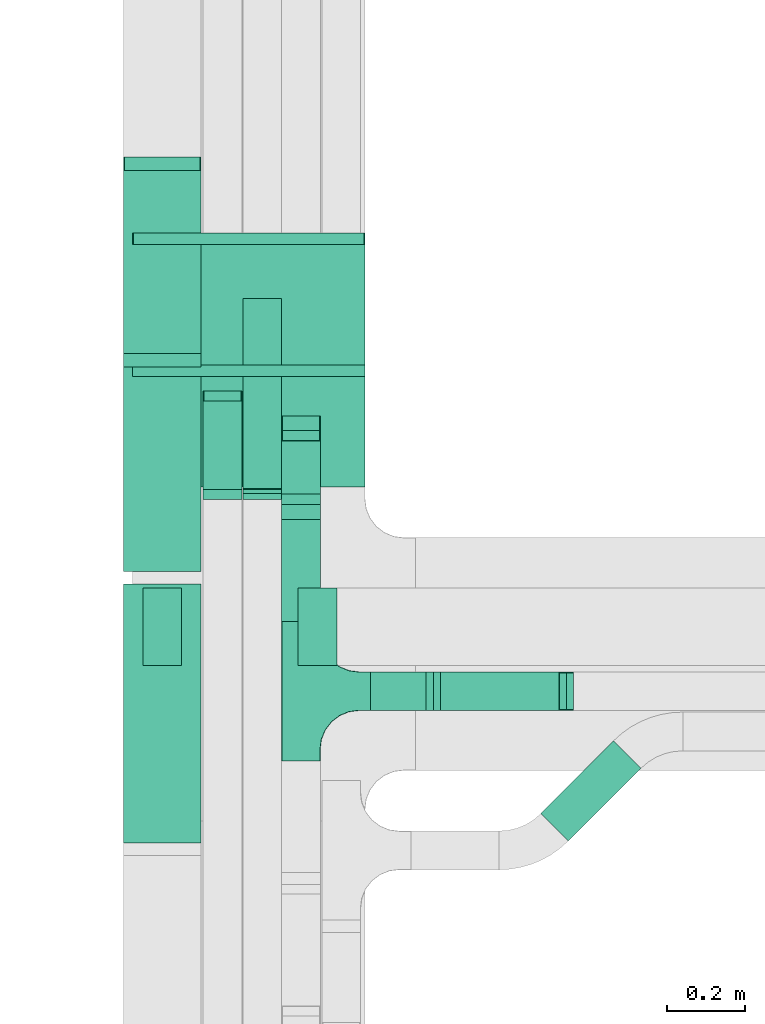
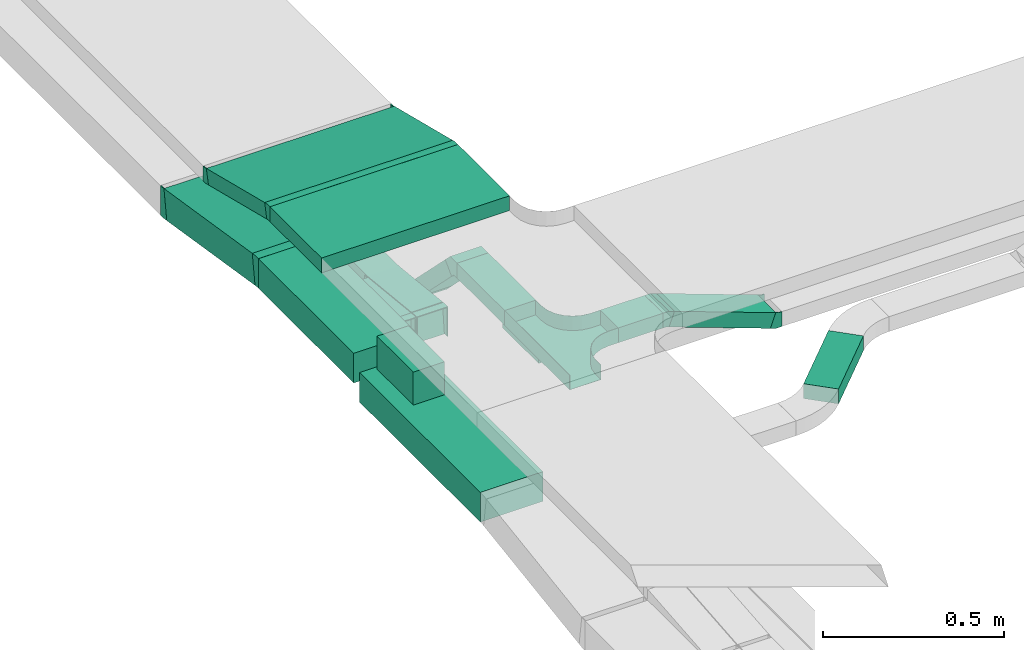
# One storey, part 31 of 38: 14 flow segments, 13 flow fittings.
"""IFC2X3 building model written with IfcOpenShell, lengths in millimetres."""

from ifc_helpers import new_model, entity, si_unit, converted_unit, derived_unit, direction, frame, frame_2d, origin, origin_2d_with_axis, place, context, subcontext, project, spatial, polyline, circle_curve, parameter, trimmed, segment, composite_curve, rectangle, outline, extrude, faceted_brep, source, transform, mapped, material, type_object, type_shapes, element, save


model = new_model("IFC2X3")

# Units and contexts
model_context = context("Model", 3, precision=0.01, world=origin(), true_north=direction((6.12303176911189e-17, 1.0)))
body_context = subcontext(model_context, "Body", "Model", "MODEL_VIEW")
ifc_project = project(units=[si_unit("LENGTHUNIT", "METRE", prefix="MILLI"), si_unit("AREAUNIT", "SQUARE_METRE"), si_unit("VOLUMEUNIT", "CUBIC_METRE"), converted_unit("PLANEANGLEUNIT", "DEGREE", entity("IfcRatioMeasure", 0.0174532925199433), si_unit("PLANEANGLEUNIT", "RADIAN"), dimensions=[0, 0, 0, 0, 0, 0, 0]), si_unit("MASSUNIT", "GRAM", prefix="KILO"), derived_unit("MASSDENSITYUNIT", [(si_unit("MASSUNIT", "GRAM", prefix="KILO"), 1), (si_unit("LENGTHUNIT", "METRE"), -3)]), derived_unit("MOMENTOFINERTIAUNIT", [(si_unit("LENGTHUNIT", "METRE"), 4)]), si_unit("TIMEUNIT", "SECOND"), si_unit("FREQUENCYUNIT", "HERTZ"), si_unit("THERMODYNAMICTEMPERATUREUNIT", "DEGREE_CELSIUS"), derived_unit("THERMALTRANSMITTANCEUNIT", [(si_unit("MASSUNIT", "GRAM", prefix="KILO"), 1), (si_unit("THERMODYNAMICTEMPERATUREUNIT", "KELVIN"), -1), (si_unit("TIMEUNIT", "SECOND"), -3)]), derived_unit("VOLUMETRICFLOWRATEUNIT", [(si_unit("LENGTHUNIT", "METRE"), 3), (si_unit("TIMEUNIT", "SECOND"), -1)]), derived_unit("MASSFLOWRATEUNIT", [(si_unit("MASSUNIT", "GRAM", prefix="KILO"), 1), (si_unit("TIMEUNIT", "SECOND"), -1)]), derived_unit("ROTATIONALFREQUENCYUNIT", [(si_unit("TIMEUNIT", "SECOND"), -1)]), si_unit("ELECTRICCURRENTUNIT", "AMPERE"), si_unit("ELECTRICVOLTAGEUNIT", "VOLT"), si_unit("POWERUNIT", "WATT"), si_unit("FORCEUNIT", "NEWTON", prefix="KILO"), si_unit("ILLUMINANCEUNIT", "LUX"), si_unit("LUMINOUSFLUXUNIT", "LUMEN"), si_unit("LUMINOUSINTENSITYUNIT", "CANDELA"), derived_unit("USERDEFINED", [(si_unit("MASSUNIT", "GRAM", prefix="KILO"), -1), (si_unit("LENGTHUNIT", "METRE"), -2), (si_unit("TIMEUNIT", "SECOND"), 3), (si_unit("LUMINOUSFLUXUNIT", "LUMEN"), 1)]), derived_unit("LINEARVELOCITYUNIT", [(si_unit("LENGTHUNIT", "METRE"), 1), (si_unit("TIMEUNIT", "SECOND"), -1)]), si_unit("PRESSUREUNIT", "PASCAL"), derived_unit("USERDEFINED", [(si_unit("LENGTHUNIT", "METRE"), -2), (si_unit("MASSUNIT", "GRAM", prefix="KILO"), 1), (si_unit("TIMEUNIT", "SECOND"), -2)]), derived_unit("LINEARFORCEUNIT", [(si_unit("MASSUNIT", "GRAM", prefix="KILO"), 1), (si_unit("LENGTHUNIT", "METRE"), 1), (si_unit("TIMEUNIT", "SECOND"), -2), (si_unit("LENGTHUNIT", "METRE"), -1)]), derived_unit("PLANARFORCEUNIT", [(si_unit("MASSUNIT", "GRAM", prefix="KILO"), 1), (si_unit("LENGTHUNIT", "METRE"), 1), (si_unit("TIMEUNIT", "SECOND"), -2), (si_unit("LENGTHUNIT", "METRE"), -2)])], contexts=[model_context])

# Site, building, storey
site_placement = place(None, frame((0.0, -0.00077364408347762, 0.0)))
site = spatial("IfcSite", under=ifc_project, at=site_placement, CompositionType="ELEMENT")
building_placement = place(site_placement, origin())
building = spatial("IfcBuilding", under=site, at=building_placement, CompositionType="ELEMENT")
storey_placement = place(building_placement, frame((0.0, 0.0, 4200.0)))
storey = spatial("IfcBuildingStorey", under=building, at=storey_placement, CompositionType="ELEMENT", Elevation=4200.0)

# Flow segments
cable_carrier_segment_type = type_object("IfcCableCarrierSegmentType", PredefinedType="CABLETRAYSEGMENT")
flow_segment_1_placement = place(storey_placement, frame((61494.0334115341, 9426.19882901523, 2776.99060375594)))
element("IfcFlowSegment", 1, at=flow_segment_1_placement, inside=storey, type_object=cable_carrier_segment_type, context=body_context, shape_type="SweptSolid", body=[
    extrude(rectangle(XDim=49.9999999999996, YDim=332.374456454339, at=frame_2d((1.4210854715202e-13, -5.27577981301874e-13), x_axis=(0.0, 1.0))), frame((0.0, 167.298804700468, 64.4617224340722), z_axis=(1.0, 0.0, 0.0), x_axis=(0.0, -0.970295726275995, 0.241921895599672)), (0.0, 0.0, 1.0), 600.000000000002),
])
flow_segment_2_placement = place(storey_placement, frame((61494.0334115341, 9123.32381905951, 2859.5)))
element("IfcFlowSegment", 2, at=flow_segment_2_placement, inside=storey, type_object=cable_carrier_segment_type, context=body_context, shape_type="SweptSolid", body=[
    extrude(rectangle(XDim=285.765874456354, YDim=600.000000000002, at=origin_2d_with_axis()), frame((300.0, 142.882937228177, 0.0), z_axis=(0.0, 0.0, 1.0), x_axis=(0.0, 1.0, 0.0)), (0.0, 0.0, 1.0), 49.9999999999995),
])
flow_segment_3_placement = place(storey_placement, frame((61878.3352641976, 9070.34806579068, 2573.66699141101)))
element("IfcFlowSegment", 3, at=flow_segment_3_placement, inside=storey, type_object=cable_carrier_segment_type, context=body_context, shape_type="SweptSolid", body=[
    extrude(rectangle(XDim=50.0000000000003, YDim=242.742091415324, at=frame_2d((-1.4210854715202e-14, -7.65609797781508e-13), x_axis=(0.0, 1.0))), frame((0.0, 103.499958989255, 103.499958989258), z_axis=(1.0, 0.0, 0.0), x_axis=(0.0, -0.707106781186556, 0.707106781186539)), (0.0, 0.0, 1.0), 99.9999999999946),
])
flow_segment_4_placement = place(storey_placement, frame((61878.3352641976, 8777.44796607604, 2757.63390080053)))
element("IfcFlowSegment", 4, at=flow_segment_4_placement, inside=storey, type_object=cable_carrier_segment_type, context=body_context, shape_type="SweptSolid", body=[
    extrude(rectangle(XDim=263.151349409973, YDim=99.9999999999946, at=frame_2d((5.54223333892878e-13, 0.0), x_axis=(1.0, 0.0))), frame((50.0, 131.575674704968, 6.82255366996287e-05), z_axis=(0.0, 5.18526979960657e-07, 1.0), x_axis=(0.0, 1.0, -5.18526979960657e-07)), (0.0, 0.0, 1.0), 49.9999999999932),
])
flow_segment_5_placement = place(storey_placement, frame((62108.3352641976, 8547.44797903922, 2757.6340372516)))
element("IfcFlowSegment", 5, at=flow_segment_5_placement, inside=storey, type_object=cable_carrier_segment_type, context=body_context, shape_type="SweptSolid", body=[
    extrude(rectangle(XDim=142.246356724546, YDim=100.000000000001, at=frame_2d((0.0, -1.08357767203415e-12), x_axis=(1.0, 0.0))), frame((71.1231783622731, 50.0, 0.0)), (0.0, 0.0, 1.0), 49.9999999999995),
])
flow_segment_6_placement = place(storey_placement, frame((62270.5406883258, 8547.44797903922, 2636.40393955217)))
element("IfcFlowSegment", 6, at=flow_segment_6_placement, inside=storey, type_object=cable_carrier_segment_type, context=body_context, shape_type="SweptSolid", body=[
    extrude(rectangle(XDim=49.9999999999965, YDim=100.000000000001, at=origin_2d_with_axis()), frame((8.55050358314202, 50.0, 141.203091126029), z_axis=(0.939692620785895, 0.0, -0.342020143325705), x_axis=(0.342020143325705, 0.0, 0.939692620785895)), (0.0, 0.0, 1.0), 344.163283664483),
])
flow_segment_7_placement = place(storey_placement, frame((61778.6830273062, 9106.66010814399, 2529.62188532879)))
element("IfcFlowSegment", 7, at=flow_segment_7_placement, inside=storey, type_object=cable_carrier_segment_type, context=body_context, shape_type="SweptSolid", body=[
    extrude(rectangle(XDim=2.73678962123566, YDim=99.9999999999946, at=frame_2d((-1.13364873044475e-12, 0.0), x_axis=(1.0, 0.0))), frame((50.0, 1.36089860066666, 0.14303620669796), z_axis=(0.0, 0.10452846326773, 0.994521895368265), x_axis=(0.0, -0.994521895368265, 0.10452846326773)), (0.0, 0.0, 1.0), 100.000000000001),
])
flow_segment_8_placement = place(storey_placement, frame((61676.2835022257, 9106.66506813766, 2504.7917187995)))
element("IfcFlowSegment", 8, at=flow_segment_8_placement, inside=storey, type_object=cable_carrier_segment_type, context=body_context, shape_type="SweptSolid", body=[
    extrude(rectangle(XDim=100.0, YDim=99.9999999999946, at=frame_2d((6.03961325396085e-14, 0.0), x_axis=(1.0, 0.0))), frame((50.0, 5.22642316339489, 74.8431041747855), z_axis=(0.0, 0.994521895368247, -0.104528463267908), x_axis=(0.0, 0.104528463267908, 0.994521895368247)), (0.0, 0.0, 1.0), 240.288708176998),
])
flow_segment_9_placement = place(storey_placement, frame((61471.1830273062, 9451.5580777934, 2548.89047953296)))
element("IfcFlowSegment", 9, at=flow_segment_9_placement, inside=storey, type_object=cable_carrier_segment_type, context=body_context, shape_type="SweptSolid", body=[
    extrude(rectangle(XDim=99.9999999999984, YDim=494.262005377991, at=frame_2d((-5.25801624462474e-13, -8.5265128291212e-14), x_axis=(0.0, 1.0))), frame((0.0, 251.910133207519, 88.0442232302831), z_axis=(1.0, 0.0, 0.0), x_axis=(0.0, -0.987688340595126, 0.156434465040307)), (0.0, 0.0, 1.0), 200.000000000007),
])
flow_segment_10_placement = place(storey_placement, frame((61471.1830273062, 8906.27941972979, 2627.66940552644)))
element("IfcFlowSegment", 10, at=flow_segment_10_placement, inside=storey, type_object=cable_carrier_segment_type, context=body_context, shape_type="SweptSolid", body=[
    extrude(rectangle(XDim=526.736320783405, YDim=200.000000000007, at=frame_2d((1.08002495835535e-12, 0.0), x_axis=(1.0, 0.0))), frame((100.0, 263.368160391717, 0.0), z_axis=(0.0, 0.0, 1.0), x_axis=(0.0, -1.0, 0.0)), (0.0, 0.0, 1.0), 100.000000000002),
])
flow_segment_11_placement = place(storey_placement, frame((62546.4770390633, 8211.11251924324, 2577.30800926447)))
element("IfcFlowSegment", 11, at=flow_segment_11_placement, inside=storey, type_object=cable_carrier_segment_type, context=body_context, shape_type="SweptSolid", body=[
    extrude(rectangle(XDim=265.58357237913, YDim=100.000000000002, at=frame_2d((-2.67164068645798e-12, 3.44257955475769e-12), x_axis=(1.0, 0.0))), frame((129.253311559847, 129.253311559845, 0.0), z_axis=(0.0, 0.0, 1.0), x_axis=(0.707106781186535, 0.70710678118656, 0.0)), (0.0, 0.0, 1.0), 49.9999999999995),
])
flow_segment_12_placement = place(storey_placement, frame((61471.1830273063, 8206.57842204228, 2582.6)))
element("IfcFlowSegment", 12, at=flow_segment_12_placement, inside=storey, type_object=cable_carrier_segment_type, context=body_context, shape_type="SweptSolid", body=[
    extrude(rectangle(XDim=667.207311601806, YDim=200.000000000007, at=frame_2d((5.40012479177676e-13, 0.0), x_axis=(1.0, 0.0))), frame((100.0, 333.603655800902, 0.0), z_axis=(0.0, 0.0, 1.0), x_axis=(0.0, 1.0, 0.0)), (0.0, 0.0, 1.0), 99.9999999999989),
])
flow_segment_13_placement = place(storey_placement, frame((61921.3628309272, 8663.78573364408, 2682.60000000003)))
element("IfcFlowSegment", 13, at=flow_segment_13_placement, inside=storey, type_object=cable_carrier_segment_type, context=body_context, shape_type="SweptSolid", body=[
    extrude(rectangle(XDim=200.0, YDim=99.9999999999946, at=frame_2d((-1.08713038571295e-12, 0.0), x_axis=(1.0, 0.0))), frame((50.0, 100.0, 0.0), z_axis=(0.0, 0.0, 1.0), x_axis=(0.0, -1.0, 0.0)), (0.0, 0.0, 1.0), 29.9999999999921),
])
flow_segment_14_placement = place(storey_placement, frame((61521.1830273063, 8663.78573364408, 2682.6)))
element("IfcFlowSegment", 14, at=flow_segment_14_placement, inside=storey, type_object=cable_carrier_segment_type, context=body_context, shape_type="SweptSolid", body=[
    extrude(rectangle(XDim=200.0, YDim=99.9999999999946, at=origin_2d_with_axis()), frame((50.0, 100.0, 0.0), z_axis=(0.0, 0.0, 1.0), x_axis=(0.0, 1.0, 0.0)), (0.0, 0.0, 1.0), 111.353041875385),
])

# Flow fittings
ifc_material = material()
cable_carrier_fitting_type_1 = type_object("IfcCableCarrierFittingType", PredefinedType="NOTDEFINED", material=ifc_material)
shared_shape_1 = source(origin(), body_context, "Body", "Brep", [
    faceted_brep([(-53.4074173710859, -124.118095489752, 25.0), (-50.0, -150.0, 25.0), (-50.0, -180.0, 25.0), (-49.1999999999934, -180.0, 25.0), (-49.1999999999926, -150.0, 25.0), (-52.6346767100545, -123.91104025367, 25.0), (-62.7046392985216, -99.6000000000037, 25.0), (-78.7236364563899, -78.7236364563991, 25.0), (-99.5999999999949, -62.7046392985315, 25.0), (-123.911040253662, -52.6346767100651, 25.0), (-150.0, -49.2000000000047, 25.0), (-180.0, -49.2000000000047, 25.0), (-180.0, -50.0, 25.0), (-150.0, -50.0, 25.0), (-124.118095489745, -53.4074173710983, 25.0), (-100.0, -63.3974596215602, 25.0), (-79.2893218813398, -79.2893218813488, 25.0), (-63.3974596215496, -100.0, 25.0), (180.0, -50.0, 25.0), (180.0, -49.2000000000047, 25.0), (150.0, -49.2000000000046, 25.0), (123.911040253717, -52.634676710066, 25.0), (99.6000000000452, -62.7046392985316, 25.0), (78.7236364564342, -78.7236364563979, 25.0), (62.7046392985581, -99.6000000000012, 25.0), (52.6346767100809, -123.911040253668, 25.0), (49.200000000007, -150.0, 25.0), (49.2000000000071, -180.0, 25.0), (50.0, -180.0, 25.0), (50.0, -150.0, 25.0), (53.4074173711136, -124.11809548975, 25.0), (63.3974596215874, -100.0, 25.0), (79.2893218813853, -79.2893218813486, 25.0), (100.0, -63.3974596215613, 25.0), (124.1180954898, -53.4074173710999, 25.0), (150.0, -50.0, 25.0), (180.0, 49.1999999999958, 25.0), (180.0, 50.0, 25.0), (-180.0, 50.0, 25.0), (-180.0, 49.1999999999958, 25.0), (-180.0, -50.0, -25.0), (-180.0, 50.0, -25.0), (180.0, 50.0, -25.0), (180.0, -50.0, -25.0), (150.0, -50.0, -25.0), (124.1180954898, -53.4074173710999, -25.0), (100.0, -63.3974596215613, -25.0), (79.2893218813853, -79.2893218813486, -25.0), (63.3974596215874, -100.0, -25.0), (53.4074173711136, -124.11809548975, -25.0), (50.0, -150.0, -25.0), (50.0, -180.0, -25.0), (-50.0, -180.0, -25.0), (-50.0, -150.0, -25.0), (-53.4074173710859, -124.118095489752, -25.0), (-63.3974596215496, -100.0, -25.0), (-79.2893218813398, -79.2893218813488, -25.0), (-100.0, -63.3974596215602, -25.0), (-124.118095489745, -53.4074173710983, -25.0), (-150.0, -50.0, -25.0), (-50.0, -150.0, -24.199999999986), (49.2000000000071, -180.0, -24.199999999986), (-49.1999999999934, -180.0, -24.199999999986), (-49.1999999999926, -150.0, -24.199999999986), (-150.0, -49.2000000000047, -24.199999999986), (-180.0, -49.2000000000047, -24.199999999986), (180.0, -49.2000000000047, -24.199999999986), (150.0, -49.2000000000047, -24.199999999986), (-180.0, 49.1999999999958, -24.199999999986), (-150.0, -50.0, -24.199999999986), (150.0, -50.0, -24.199999999986), (180.0, 49.1999999999958, -24.199999999986), (49.200000000007, -150.0, -24.199999999986), (50.0, -150.0, -24.199999999986), (-123.911040253662, -52.6346767100651, -24.199999999986), (-99.5999999999949, -62.7046392985315, -24.199999999986), (-78.7236364563899, -78.7236364563991, -24.199999999986), (-62.7046392985217, -99.6000000000036, -24.199999999986), (-52.6346767100546, -123.91104025367, -24.199999999986), (52.6346767100807, -123.911040253669, -24.199999999986), (62.7046392985577, -99.6000000000018, -24.199999999986), (78.7236364564338, -78.7236364563983, -24.199999999986), (99.6000000000446, -62.704639298532, -24.199999999986), (123.911040253716, -52.6346767100662, -24.199999999986)], [[[0, 1, 2, 3, 4, 5, 6, 7, 8, 9, 10, 11, 12, 13, 14, 15, 16, 17]], [[18, 19, 20, 21, 22, 23, 24, 25, 26, 27, 28, 29, 30, 31, 32, 33, 34, 35]], [[36, 37, 38, 39]], [[40, 41, 42, 43, 44, 45, 46, 47, 48, 49, 50, 51, 52, 53, 54, 55, 56, 57, 58, 59]], [[2, 1, 60, 53, 52]], [[3, 2, 52, 51, 28, 27, 61, 62]], [[4, 3, 62, 63]], [[11, 10, 64, 65]], [[20, 19, 66, 67]], [[39, 38, 41, 40, 12, 11, 65, 68]], [[13, 12, 40, 59, 69]], [[18, 35, 70, 44, 43]], [[19, 18, 43, 42, 37, 36, 71, 66]], [[27, 26, 72, 61]], [[29, 28, 51, 50, 73]], [[38, 37, 42, 41]], [[36, 39, 68, 71]], [[68, 65, 64, 74, 75, 76, 77, 78, 63, 62, 61, 72, 79, 80, 81, 82, 83, 67, 66, 71]], [[14, 13, 69, 59, 58]], [[58, 57, 15, 14]], [[15, 57, 56, 16]], [[0, 17, 55, 54]], [[0, 54, 53, 60, 1]], [[55, 17, 16, 56]], [[5, 4, 63, 78]], [[6, 5, 78, 77]], [[7, 6, 77, 76]], [[8, 7, 76, 75]], [[9, 8, 75, 74]], [[10, 9, 74, 64]], [[21, 20, 67, 83]], [[22, 21, 83, 82]], [[23, 22, 82, 81]], [[81, 80, 24, 23]], [[24, 80, 79, 25]], [[79, 72, 26, 25]], [[30, 29, 73, 50, 49]], [[31, 30, 49, 48]], [[31, 48, 47, 32]], [[33, 32, 47, 46]], [[45, 34, 33, 46]], [[34, 45, 44, 70, 35]]]),
])
type_shapes(cable_carrier_fitting_type_1, [shared_shape_1])
flow_fitting_1_placement = place(storey_placement, frame((61928.3352641976, 8597.44797903921, 2782.63403725161), z_axis=(0.0, 0.0, 1.0), x_axis=(0.0, 1.0, 0.0)))
element("IfcFlowFitting", 15, at=flow_fitting_1_placement, inside=storey, type_object=cable_carrier_fitting_type_1, material=ifc_material, Name="470_DKC_S5_T", context=body_context, shape_type="MappedRepresentation", body=[
    mapped(shared_shape_1, transform((0.0, 0.0, 0.0), scale=1.0)),
])
cable_carrier_fitting_type_2 = type_object("IfcCableCarrierFittingType", PredefinedType="NOTDEFINED", material=ifc_material)
shared_shape_2 = source(origin(), body_context, "Body", "Brep", [
    faceted_brep([(-13.2636792165848, -50.0, 100.0), (-13.2636792165844, 50.0, 100.0), (-13.2636792165844, 50.0, 97.4600000101635), (-13.2636792165847, -47.4600000101599, 97.4600000101635), (-13.2636792165847, -47.4600000101599, -97.4600000101564), (-13.2636792165844, 50.0, -97.4600000101564), (-13.2636792165844, 50.0, -100.0), (-13.2636792165848, -50.0, -100.0), (20.922104567627, -47.3095204670457, 100.0), (20.922104567627, -47.3095204670457, -100.0), (5.27865806360387, 51.4593135924681, -100.0), (5.27865806360387, 51.4593135924681, -97.4600000101564), (20.5247610280142, -44.8007920919689, -97.4600000101564), (20.5247610280142, -44.8007920919689, 97.4600000101635), (5.27865806360387, 51.4593135924681, 97.4600000101635), (5.27865806360387, 51.4593135924681, 100.0), (3.93508534123125, -50.0, 100.0), (-3.9350853412305, 50.0, 100.0), (-3.9350853412305, 50.0, 97.4600000101635), (3.73518300669629, -47.46000001016, 97.4600000101635), (3.73518300669629, -47.46000001016, -97.4600000101564), (-3.9350853412305, 50.0, -97.4600000101564), (-3.9350853412305, 50.0, -100.0), (3.93508534123121, -50.0, -100.0)], [[[0, 1, 2, 3, 4, 5, 6, 7]], [[8, 9, 10, 11, 12, 13, 14, 15]], [[1, 0, 16, 8, 15, 17]], [[2, 1, 17, 18]], [[3, 2, 18, 14, 13, 19]], [[4, 3, 19, 20]], [[5, 4, 20, 12, 11, 21]], [[6, 5, 21, 22]], [[7, 6, 22, 10, 9, 23]], [[0, 7, 23, 16]], [[18, 17, 15, 14]], [[20, 19, 13, 12]], [[22, 21, 11, 10]], [[16, 23, 9, 8]]]),
])
type_shapes(cable_carrier_fitting_type_2, [shared_shape_2])
for number, where, z_axis, x_axis in (
    (16, (61571.1830273062, 9960.65700227204, 2596.2), (-1.0, 0.0, 0.0), (0.0, -1.0, 0.0)),
    (17, (61571.1830273062, 9446.2794197298, 2677.66940552648), (1.0, 0.0, 0.0), (0.0, -0.987688340595126, 0.156434465040307)),
):
    element("IfcFlowFitting", number, at=place(storey_placement, frame(where, z_axis=z_axis, x_axis=x_axis)), inside=storey, type_object=cable_carrier_fitting_type_2, material=ifc_material, context=body_context, shape_type="MappedRepresentation", body=[
        mapped(shared_shape_2, transform((0.0, 0.0, 0.0), scale=1.0)),
    ])
cable_carrier_fitting_type_3 = type_object("IfcCableCarrierFittingType", PredefinedType="NOTDEFINED", material=ifc_material)
shared_shape_3 = source(origin(), body_context, "Body", "Brep", [
    faceted_brep([(-11.7531508496595, -25.0, 300.0), (-11.7531508496593, 25.0, 300.0), (-11.7531508496593, 25.0, 297.460000010164), (-11.7531508496595, -22.46000001016, 297.460000010164), (-11.7531508496595, -22.46000001016, -297.460000010156), (-11.7531508496593, 25.0, -297.460000010156), (-11.7531508496593, 25.0, -300.0), (-11.7531508496595, -25.0, -300.0), (17.4520794296941, -21.4140486240818, 300.0), (17.4520794296941, -21.4140486240818, -300.0), (5.35598464971072, 27.100737689718, -300.0), (5.35598464971072, 27.100737689718, -297.460000010156), (16.8375978173289, -18.949497489199, -297.460000010156), (16.8375978173289, -18.949497489199, 297.460000010164), (5.35598464971072, 27.100737689718, 297.460000010164), (5.35598464971072, 27.100737689718, 300.0), (3.069614022573, -25.0, 300.0), (-3.06961402257224, 25.0, 300.0), (-3.06961402257224, 25.0, 297.460000010164), (2.75774123912706, -22.46000001016, 297.460000010164), (2.75774123912706, -22.46000001016, -297.460000010156), (-3.06961402257224, 25.0, -297.460000010156), (-3.06961402257224, 25.0, -300.0), (3.06961402257294, -25.0, -300.0)], [[[0, 1, 2, 3, 4, 5, 6, 7]], [[8, 9, 10, 11, 12, 13, 14, 15]], [[1, 0, 16, 8, 15, 17]], [[2, 1, 17, 18]], [[3, 2, 18, 14, 13, 19]], [[4, 3, 19, 20]], [[5, 4, 20, 12, 11, 21]], [[6, 5, 21, 22]], [[7, 6, 22, 10, 9, 23]], [[0, 7, 23, 16]], [[18, 17, 15, 14]], [[20, 19, 13, 12]], [[22, 21, 11, 10]], [[16, 23, 9, 8]]]),
])
type_shapes(cable_carrier_fitting_type_3, [shared_shape_3])
for number, where, z_axis, x_axis in (
    (18, (61794.0334115341, 9766.15242306588, 2798.40465238002), (-1.0, 0.0, 0.0), (0.0, -1.0, 0.0)),
    (19, (61794.0334115341, 9420.84284436552, 2884.5), (-1.0, 0.0, 0.0), (0.0, 1.0, 0.0)),
):
    element("IfcFlowFitting", number, at=place(storey_placement, frame(where, z_axis=z_axis, x_axis=x_axis)), inside=storey, type_object=cable_carrier_fitting_type_3, material=ifc_material, context=body_context, shape_type="MappedRepresentation", body=[
        mapped(shared_shape_3, transform((0.0, 0.0, 0.0), scale=1.0)),
    ])
cable_carrier_fitting_type_4 = type_object("IfcCableCarrierFittingType", PredefinedType="NOTDEFINED", material=ifc_material)
shared_shape_4 = source(origin(), body_context, "Body", "Brep", [
    faceted_brep([(-27.7817459305214, -25.0, 50.0), (-27.7817459305212, 25.0, 50.0), (-27.7817459305212, 25.0, 47.4600000101635), (-27.7817459305214, -22.4600000101599, 47.4600000101635), (-27.7817459305214, -22.4600000101599, -47.4600000101565), (-27.7817459305212, 25.0, -47.4600000101565), (-27.7817459305212, 25.0, -50.0), (-27.7817459305214, -25.0, -50.0), (37.3223304703378, 1.96699141101392, 50.0), (37.3223304703378, 1.96699141101391, -50.0), (1.96699141100637, 37.3223304703372, -50.0), (1.96699141100638, 37.3223304703372, -47.4600000101565), (35.526279253308, 3.76304262804334, -47.4600000101565), (35.526279253308, 3.76304262804333, 47.4600000101635), (1.96699141100637, 37.3223304703372, 47.4600000101635), (1.96699141100637, 37.3223304703372, 50.0), (10.3553390593295, -25.0, 50.0), (-10.3553390593287, 25.0, 50.0), (-10.3553390593287, 25.0, 47.4600000101635), (9.30323661510993, -22.46000001016, 47.4600000101635), (9.30323661510993, -22.46000001016, -47.4600000101565), (-10.3553390593287, 25.0, -47.4600000101565), (-10.3553390593287, 25.0, -50.0), (10.3553390593293, -25.0, -50.0)], [[[0, 1, 2, 3, 4, 5, 6, 7]], [[8, 9, 10, 11, 12, 13, 14, 15]], [[1, 0, 16, 8, 15, 17]], [[2, 1, 17, 18]], [[3, 2, 18, 14, 13, 19]], [[4, 3, 19, 20]], [[5, 4, 20, 12, 11, 21]], [[6, 5, 21, 22]], [[7, 6, 22, 10, 9, 23]], [[0, 7, 23, 16]], [[18, 17, 15, 14]], [[20, 19, 13, 12]], [[22, 21, 11, 10]], [[16, 23, 9, 8]]]),
])
type_shapes(cable_carrier_fitting_type_4, [shared_shape_4])
for number, where, z_axis, x_axis in (
    (20, (61928.3352641976, 9279.3149751802, 2571.7), (-1.0, 0.0, 0.0), (0.0, -1.0, 0.0)),
    (21, (61928.3352641976, 9068.38107437967, 2782.63390080052), (1.0, 0.0, 0.0), (0.0, -0.707106781186476, 0.707106781186619)),
):
    element("IfcFlowFitting", number, at=place(storey_placement, frame(where, z_axis=z_axis, x_axis=x_axis)), inside=storey, type_object=cable_carrier_fitting_type_4, material=ifc_material, context=body_context, shape_type="MappedRepresentation", body=[
        mapped(shared_shape_4, transform((0.0, 0.0, 0.0), scale=1.0)),
    ])
cable_carrier_fitting_type_5 = type_object("IfcCableCarrierFittingType", PredefinedType="NOTDEFINED", material=ifc_material)
shared_shape_5 = source(origin(), body_context, "Body", "Brep", [
    faceted_brep([(-14.6979839389677, -25.0, 50.0), (-14.6979839389676, 25.0, 50.0), (-14.6979839389676, 25.0, 47.4600000101635), (-14.6979839389677, -22.4600000101599, 47.4600000101635), (-14.6979839389677, -22.46000001016, -47.4600000101565), (-14.6979839389676, 25.0, -47.4600000101565), (-14.6979839389676, 25.0, -50.0), (-14.6979839389677, -25.0, -50.0), (22.3620906310219, -18.465308946242, 50.0), (22.3620906310219, -18.465308946242, -50.0), (5.26108346473437, 28.519322093052, -50.0), (5.26108346473436, 28.519322093052, -47.4600000101565), (21.4933594704494, -16.0784896989931, -47.4600000101565), (21.4933594704494, -16.0784896989931, 47.4600000101635), (5.26108346473437, 28.519322093052, 47.4600000101635), (5.26108346473436, 28.519322093052, 50.0), (4.40817451771314, -25.0, 50.0), (-4.40817451771236, 25.0, 50.0), (-4.40817451771236, 25.0, 47.4600000101635), (3.96030398850493, -22.46000001016, 47.4600000101635), (3.96030398850493, -22.46000001016, -47.4600000101565), (-4.40817451771236, 25.0, -47.4600000101565), (-4.40817451771236, 25.0, -50.0), (4.40817451771306, -25.0, -50.0)], [[[0, 1, 2, 3, 4, 5, 6, 7]], [[8, 9, 10, 11, 12, 13, 14, 15]], [[1, 0, 16, 8, 15, 17]], [[2, 1, 17, 18]], [[3, 2, 18, 14, 13, 19]], [[4, 3, 19, 20]], [[5, 4, 20, 12, 11, 21]], [[6, 5, 21, 22]], [[7, 6, 22, 10, 9, 23]], [[0, 7, 23, 16]], [[18, 17, 15, 14]], [[20, 19, 13, 12]], [[22, 21, 11, 10]], [[16, 23, 9, 8]]]),
])
type_shapes(cable_carrier_fitting_type_5, [shared_shape_5])
for number, where, z_axis, x_axis in (
    (22, (62616.3104769618, 8597.44797903922, 2654.8692484984), (0.0, 1.0, 0.0), (-1.0, 0.0, 0.0)),
    (23, (62265.2796048611, 8597.44797903922, 2782.6340372516), (0.0, 1.0, 0.0), (1.0, 0.0, 0.0)),
):
    element("IfcFlowFitting", number, at=place(storey_placement, frame(where, z_axis=z_axis, x_axis=x_axis)), inside=storey, type_object=cable_carrier_fitting_type_5, material=ifc_material, context=body_context, shape_type="MappedRepresentation", body=[
        mapped(shared_shape_5, transform((0.0, 0.0, 0.0), scale=1.0)),
    ])
cable_carrier_fitting_type_6 = type_object("IfcCableCarrierFittingType", PredefinedType="NOTDEFINED", material=ifc_material)
shared_shape_6 = source(origin(), body_context, "Body", "Brep", [
    faceted_brep([(-10.502816824733, -50.0, 50.0), (-10.5028168247327, 50.0, 50.0), (-10.5028168247327, 50.0, 47.4600000101635), (-10.502816824733, -47.46000001016, 47.4600000101635), (-10.502816824733, -47.46000001016, -47.4600000101565), (-10.5028168247327, 50.0, -47.4600000101565), (-10.5028168247327, 50.0, -50.0), (-10.502816824733, -50.0, -50.0), (15.6717044586354, -48.628251465739, 50.0), (15.6717044586354, -48.6282514657389, -50.0), (5.21885813184378, 50.8239380710856, -50.0), (5.21885813184378, 50.8239380710856, -47.4600000101565), (15.4062021629969, -46.102165861608, -47.4600000101565), (15.4062021629969, -46.102165861608, 47.4600000101635), (5.21885813184378, 50.8239380710856, 47.4600000101635), (5.21885813184378, 50.8239380710856, 50.0), (2.62038896415889, -50.0, 50.0), (-2.62038896415818, 50.0, 50.0), (-2.62038896415818, 50.0, 47.4600000101635), (2.48727320531208, -47.46000001016, 47.4600000101635), (2.48727320531208, -47.46000001016, -47.4600000101565), (-2.62038896415818, 50.0, -47.4600000101565), (-2.62038896415818, 50.0, -50.0), (2.62038896415887, -50.0, -50.0)], [[[0, 1, 2, 3, 4, 5, 6, 7]], [[8, 9, 10, 11, 12, 13, 14, 15]], [[1, 0, 16, 8, 15, 17]], [[2, 1, 17, 18]], [[3, 2, 18, 14, 13, 19]], [[4, 3, 19, 20]], [[5, 4, 20, 12, 11, 21]], [[6, 5, 21, 22]], [[7, 6, 22, 10, 9, 23]], [[0, 7, 23, 16]], [[18, 17, 15, 14]], [[20, 19, 13, 12]], [[22, 21, 11, 10]], [[16, 23, 9, 8]]]),
])
type_shapes(cable_carrier_fitting_type_6, [shared_shape_6])
for number, where, z_axis, x_axis in (
    (24, (61828.6830273062, 9101.44125001214, 2580.73189581327), (1.0, 0.0, 0.0), (0.0, -0.994521895368246, 0.104528463267915)),
    (25, (61726.2835022257, 9101.44621000582, 2580.73266627696), (1.0, 0.0, 0.0), (0.0, -0.994521895368246, 0.104528463267915)),
    (26, (61726.2835022257, 9361.30915408807, 2553.41997026523), (1.0, 0.0, 0.0), (0.0, 0.994521895368246, -0.10452846326791)),
):
    element("IfcFlowFitting", number, at=place(storey_placement, frame(where, z_axis=z_axis, x_axis=x_axis)), inside=storey, type_object=cable_carrier_fitting_type_6, material=ifc_material, context=body_context, shape_type="MappedRepresentation", body=[
        mapped(shared_shape_6, transform((0.0, 0.0, 0.0), scale=1.0)),
    ])
cable_carrier_fitting_type_7 = type_object("IfcCableCarrierFittingType", Name="470_DKC_S5_CS 90 internal vertical angle:-", PredefinedType="NOTDEFINED", material=ifc_material)
shared_shape_7 = source(origin(), body_context, "Body", "SweptSolid", [
    extrude(outline(composite_curve([segment(polyline([(-247.713192483587, -56.7136792843577), (-8.30173159786339, -56.7136792843577)]), True, "CONTINUOUS"), segment(trimmed(circle_curve(frame_2d((-8.30173159786372, 158.286320715641), x_axis=(0.0, -1.0)), 214.999999999999), [parameter(0.0)], [parameter(6.00454625180131)], True, "PARAMETER"), True, "CONTINUOUS"), segment(polyline([(14.1888540979927, -55.5341028997302), (252.286807516414, -30.4898983526584)]), True, "CONTINUOUS"), segment(polyline([(252.286807516413, -30.4898983526584), (241.826069983457, 68.9614614684454)]), True, "CONTINUOUS"), segment(polyline([(241.826069983457, 68.9614614684454), (3.72811656503613, 43.9172569213736)]), True, "CONTINUOUS"), segment(trimmed(circle_curve(frame_2d((-8.30173159786372, 158.286320715641), x_axis=(0.0, -1.0)), 114.999999999999), [parameter(0.0)], [parameter(6.00454625180131)], True, "PARAMETER"), False, "CONTINUOUS"), segment(polyline([(-8.30173159786339, 43.2863207156426), (-247.713192483587, 43.2863207156426)]), True, "CONTINUOUS"), segment(polyline([(-247.713192483587, 43.2863207156426), (-247.713192483587, -56.7136792843577)]), True, "CONTINUOUS")], self_intersect=False)), frame((-0.352116109588301, 6.71367928435028, -50.0)), (0.0, 0.0, 1.0), 99.9999999999999),
])
type_shapes(cable_carrier_fitting_type_7, [shared_shape_7])
flow_fitting_2_placement = place(storey_placement, frame((61828.6830273062, 9361.3147093859, 2553.4180945999), z_axis=(1.0, 0.0, 0.0), x_axis=(0.0, 0.994521895368246, -0.104528463267915)))
element("IfcFlowFitting", 27, at=flow_fitting_2_placement, inside=storey, type_object=cable_carrier_fitting_type_7, material=ifc_material, Name="470_DKC_S5_CS 90 internal vertical angle:-", ObjectType="470_DKC_S5_CS 90 internal vertical angle:-", context=body_context, shape_type="MappedRepresentation", body=[
    mapped(shared_shape_7, transform((0.0, 0.0, 0.0), scale=1.0)),
])

save(model, "model.ifc")
